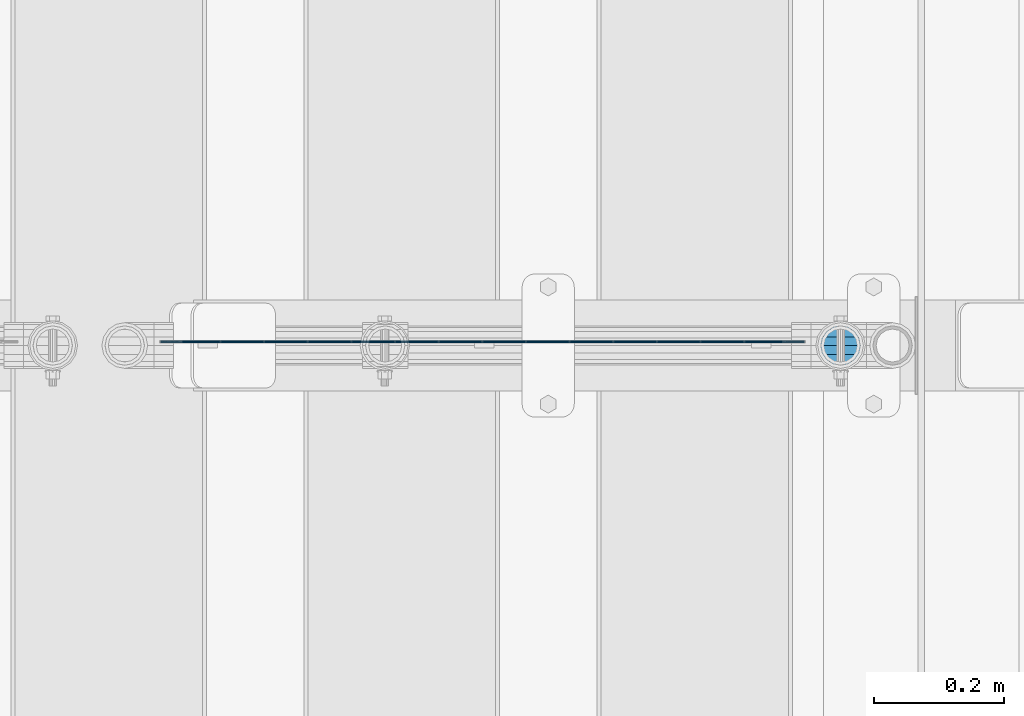
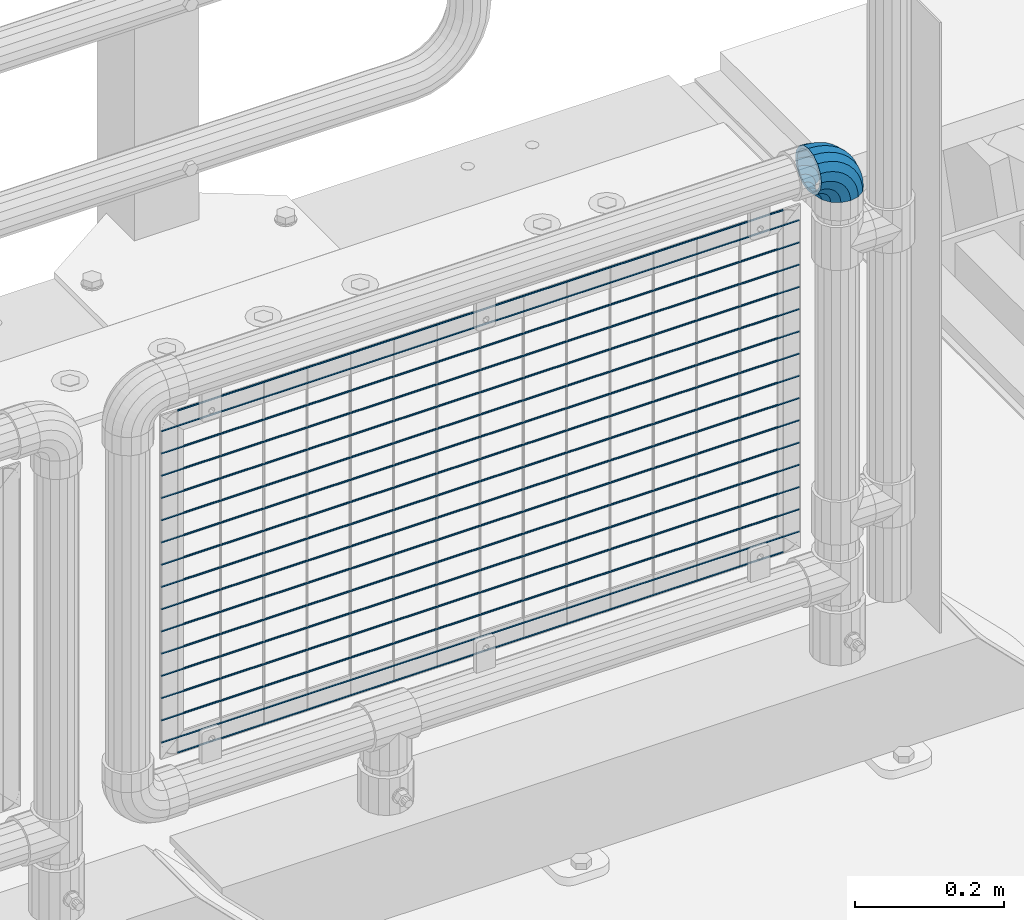
# One storey, part 190 of 270: 17 beams, 1 member.
"""IFC2X3 building model written with IfcOpenShell, lengths in millimetres."""

from ifc_helpers import new_model, si_unit, frame, origin_with_axes, place, context, subcontext, project, spatial, faceted_brep, material, type_object, element, save


model = new_model("IFC2X3")

# Units and contexts
model_context = context("Model", 3, precision=1e-05, world=origin_with_axes())
body_context = subcontext(model_context, "Body", "Model", "MODEL_VIEW")
ifc_project = project(units=[si_unit("LENGTHUNIT", "METRE", prefix="MILLI"), si_unit("AREAUNIT", "SQUARE_METRE"), si_unit("VOLUMEUNIT", "CUBIC_METRE"), si_unit("MASSUNIT", "GRAM", prefix="KILO"), si_unit("TIMEUNIT", "SECOND"), si_unit("PLANEANGLEUNIT", "RADIAN"), si_unit("SOLIDANGLEUNIT", "STERADIAN"), si_unit("THERMODYNAMICTEMPERATUREUNIT", "DEGREE_CELSIUS"), si_unit("LUMINOUSINTENSITYUNIT", "LUMEN")], contexts=[model_context])

# Site, building, storey
site_placement = place(None, origin_with_axes())
site = spatial("IfcSite", under=ifc_project, at=site_placement, CompositionType="ELEMENT")
building_placement = place(site_placement, origin_with_axes())
building = spatial("IfcBuilding", under=site, at=building_placement, Name="Standard", CompositionType="ELEMENT")
storey_placement = place(building_placement, origin_with_axes())
storey = spatial("IfcBuildingStorey", under=building, at=storey_placement, Name="Undefined", CompositionType="ELEMENT", Elevation=0.0)

# Beams
ifc_material = material(Name="Misc_Undefined")
beam_type = type_object("IfcBeamType", Name="D3", PredefinedType="NOTDEFINED")
for number, where, z_axis, x_axis in (
    (1, (18749.61, -16329.5000116654, 633.023), (0.0, 0.0, 1.0), (1.0, 0.0, 0.0)),
    (2, (18749.61, -16329.5000116615, 815.168), (0.0, 0.0, 1.0), (1.0, 0.0, 0.0)),
    (3, (18749.61, -16329.5000116646, 669.452), (0.0, 0.0, 1.0), (1.0, 0.0, 0.0)),
    (4, (18749.61, -16329.5000116662, 596.594000000001), (0.0, 0.0, 1.0), (1.0, 0.0, 0.0)),
    (5, (18749.61, -16329.5000116669, 560.165), (0.0, 0.0, 1.0), (1.0, 0.0, 0.0)),
    (6, (18749.61, -16329.5000116623, 778.739), (0.0, 0.0, 1.0), (1.0, 0.0, 0.0)),
    (7, (18749.61, -16329.5000116677, 523.736), (0.0, 0.0, 1.0), (1.0, 0.0, 0.0)),
    (8, (18749.61, -16329.5000116608, 851.597), (0.0, 0.0, 1.0), (1.0, 0.0, 0.0)),
    (9, (18749.61, -16329.5000116685, 487.307), (0.0, 0.0, 1.0), (1.0, 0.0, 0.0)),
    (10, (18749.61, -16329.5000116639, 705.881), (0.0, 0.0, 1.0), (1.0, 0.0, 0.0)),
    (11, (18749.61, -16329.5000116692, 450.878), (0.0, 0.0, 1.0), (1.0, 0.0, 0.0)),
    (12, (18749.61, -16329.50001166, 888.026), (0.0, 0.0, 1.0), (1.0, 0.0, 0.0)),
    (13, (18749.61, -16329.5000116631, 742.31), (0.0, 0.0, 1.0), (1.0, 0.0, 0.0)),
    (14, (18749.61, -16329.50001167, 414.449), (0.0, 0.0, 1.0), (1.0, 0.0, 0.0)),
):
    element("IfcBeam", number, at=place(storey_placement, frame(where, z_axis=z_axis, x_axis=x_axis)), inside=storey, type_object=beam_type, material=ifc_material, ObjectType="D3", context=body_context, shape_type="Brep", body=[
        faceted_brep([(0.0, -1.5, 0.0), (0.0, -0.75, -1.29903810567669), (988.39000000024, -0.750000000001819, -1.29903810567669), (988.39000000024, -1.50000000000182, 0.0), (0.0, 0.75, -1.29903810567669), (988.390000000243, 0.749999999998181, -1.29903810567669), (0.0, 1.5, 0.0), (988.39000000024, 1.49999999999818, 0.0), (0.0, 0.75, 1.29903810567669), (988.390000000243, 0.749999999998181, 1.29903810567669), (0.0, -0.75, 1.29903810567669), (988.39000000024, -0.750000000001819, 1.29903810567669)], [[[0, 1, 2, 3]], [[1, 4, 5, 2]], [[4, 6, 7, 5]], [[6, 8, 9, 7]], [[8, 10, 11, 9]], [[10, 0, 3, 11]], [[5, 7, 9, 11, 3, 2]], [[10, 8, 6, 4, 1, 0]]]),
    ])
beam_1_placement = place(storey_placement, frame((18774.61, -16329.5000169757, 353.02), z_axis=(0.0, 0.0, 1.0), x_axis=(1.0, 0.0, 0.0)))
element("IfcBeam", 15, at=beam_1_placement, inside=storey, type_object=beam_type, material=ifc_material, ObjectType="D3", context=body_context, shape_type="Brep", body=[
    faceted_brep([(0.0, -1.5, 0.0), (0.0, -0.75, -1.29903810567669), (938.39000000009, -0.750000000003638, -1.29903810567669), (938.390000000094, -1.50000000000364, 0.0), (0.0, 0.75, -1.29903810567669), (938.390000000094, 0.749999999996362, -1.29903810567663), (0.0, 1.5, 0.0), (938.390000000094, 1.49999999999818, 0.0), (0.0, 0.75, 1.29903810567669), (938.390000000094, 0.749999999996362, 1.29903810567669), (0.0, -0.75, 1.29903810567669), (938.39000000009, -0.750000000003638, 1.29903810567669)], [[[0, 1, 2, 3]], [[1, 4, 5, 2]], [[4, 6, 7, 5]], [[6, 8, 9, 7]], [[8, 10, 11, 9]], [[10, 0, 3, 11]], [[5, 7, 9, 11, 3, 2]], [[10, 8, 6, 4, 1, 0]]]),
])
beam_2_placement = place(storey_placement, frame((18749.61, -16329.5000116708, 378.02), z_axis=(0.0, 0.0, 1.0), x_axis=(1.0, 0.0, 0.0)))
element("IfcBeam", 16, at=beam_2_placement, inside=storey, type_object=beam_type, material=ifc_material, ObjectType="D3", context=body_context, shape_type="Brep", body=[
    faceted_brep([(0.0, -1.5, 0.0), (0.0, -0.75, -1.29903810567669), (988.39000000024, -0.750000000001819, -1.29903810567669), (988.39000000024, -1.50000000000182, 0.0), (0.0, 0.75, -1.29903810567669), (988.390000000243, 0.749999999998181, -1.29903810567669), (0.0, 1.5, 0.0), (988.39000000024, 1.49999999999818, 0.0), (0.0, 0.75, 1.29903810567669), (988.390000000243, 0.749999999998181, 1.29903810567669), (0.0, -0.75, 1.29903810567669), (988.39000000024, -0.750000000001819, 1.29903810567669)], [[[0, 1, 2, 3]], [[1, 4, 5, 2]], [[4, 6, 7, 5]], [[6, 8, 9, 7]], [[8, 10, 11, 9]], [[10, 0, 3, 11]], [[5, 7, 9, 11, 3, 2]], [[10, 8, 6, 4, 1, 0]]]),
])
beam_3_placement = place(storey_placement, frame((18774.61, -16329.50001696, 913.02), z_axis=(0.0, 0.0, 1.0), x_axis=(1.0, 0.0, 0.0)))
element("IfcBeam", 17, at=beam_3_placement, inside=storey, type_object=beam_type, material=ifc_material, ObjectType="D3", context=body_context, shape_type="Brep", body=[
    faceted_brep([(0.0, -1.5, 0.0), (0.0, -0.75, -1.29903810567669), (938.39000000009, -0.750000000003638, -1.29903810567669), (938.390000000094, -1.50000000000364, 0.0), (0.0, 0.75, -1.29903810567669), (938.390000000094, 0.749999999996362, -1.29903810567663), (0.0, 1.5, 0.0), (938.390000000094, 1.49999999999818, 0.0), (0.0, 0.75, 1.29903810567669), (938.390000000094, 0.749999999996362, 1.29903810567669), (0.0, -0.75, 1.29903810567669), (938.39000000009, -0.750000000003638, 1.29903810567669)], [[[0, 1, 2, 3]], [[1, 4, 5, 2]], [[4, 6, 7, 5]], [[6, 8, 9, 7]], [[8, 10, 11, 9]], [[10, 0, 3, 11]], [[5, 7, 9, 11, 3, 2]], [[10, 8, 6, 4, 1, 0]]]),
])

# Member
member_type = type_object("IfcMemberType", PredefinedType="NOTDEFINED")
member_placement = place(storey_placement, frame((19794.0, -16335.5, 924.85), z_axis=(0.707106781186547, 0.0, 0.707106781186548), x_axis=(-0.707106781186548, 0.0, 0.707106781186548)))
element("IfcMember", 18, at=member_placement, inside=storey, type_object=member_type, material=ifc_material, context=body_context, shape_type="Brep", body=[
    faceted_brep([(0.0, -35.1499999999996, 0.0), (9.51152146006916, -32.4743655677721, -9.51152146006947), (13.2759578763396, -32.4743655677721, -6.29638902527765), (5.36946880023311, -35.1499999999996, 4.58595959347795), (17.5749999999998, -24.8548033587067, -17.5750000000001), (19.9787556631106, -24.8548033587067, -15.5219987155636), (22.962844107702, -13.4513226476338, -22.9628441077024), (24.4574219585238, -13.4513226476338, -21.686354032394), (24.8548033587069, 0.0, -24.8548033587072), (26.0301204183136, 0.0, -23.8509877588015), (22.962844107702, 13.4513226476338, -22.9628441077024), (24.4574219585238, 13.4513226476338, -21.686354032394), (17.5749999999998, 24.8548033587067, -17.5750000000001), (19.9787556631106, 24.8548033587067, -15.5219987155636), (9.51152146006916, 32.4743655677721, -9.51152146006947), (13.2759578763396, 32.4743655677721, -6.29638902527765), (0.0, 35.1499999999996, 0.0), (5.36946880023311, 35.1499999999996, 4.58595959347795), (-9.51152146006962, 32.4743655677721, 9.5115214600693), (-2.53702027587315, 32.4743655677721, 15.4683082122336), (-17.5750000000003, 24.8548033587067, 17.5749999999999), (-9.23981806264419, 24.8548033587067, 24.6939179025195), (-22.9628441077025, 13.4513226476338, 22.9628441077022), (-13.7184843580576, 13.4513226476338, 30.8582732193499), (-24.8548033587074, 0.0, 24.8548033587071), (-15.2911828178471, 0.0, 33.0229069457573), (-22.9628441077025, -13.4513226476338, 22.9628441077022), (-13.7184843580576, -13.4513226476338, 30.8582732193499), (-17.5750000000003, -24.8548033587067, 17.5749999999999), (-9.23981806264419, -24.8548033587067, 24.6939179025195), (-9.51152146006962, -32.4743655677721, 9.5115214600693), (-2.53702027587315, -32.4743655677721, 15.4683082122336), (0.0, -30.3500000000004, 0.0), (-8.21265081971887, -28.0397438117179, 8.2126508197185), (-1.45732902223699, -28.0397438117179, 13.982240691038), (5.36946880023311, -30.3500000000004, 4.58595959347795), (-15.1750000000002, -21.4606908090118, 15.1749999999999), (-7.24480876131247, -21.4606908090118, 21.9480231689948), (-19.8270929919993, -11.6144421722802, 19.827092991999), (-11.1118790903536, -11.6144421722802, 27.2705888550771), (-21.4606908090118, 0.0, 21.4606908090117), (-12.4698136068432, 0.0, 29.1396253727576), (-19.8270929919993, 11.6144421722802, 19.827092991999), (-11.1118790903536, 11.6144421722802, 27.2705888550771), (-15.1750000000002, 21.4606908090118, 15.1749999999999), (-7.24480876131247, 21.4606908090118, 21.9480231689948), (-8.21265081971887, 28.0397438117179, 8.2126508197185), (-1.45732902223699, 28.0397438117179, 13.982240691038), (0.0, 30.3500000000004, 0.0), (5.36946880023311, 30.3500000000004, 4.58595959347795), (8.21265081971842, 28.0397438117179, -8.21265081971868), (12.1962666227034, 28.0397438117179, -4.81032150408211), (15.1749999999997, 21.4606908090118, -15.175), (17.9837463617789, 21.4606908090118, -12.7761039820388), (19.8270929919988, 11.6144421722802, -19.8270929919991), (21.85081669082, 11.6144421722802, -18.0986696681213), (21.4606908090116, 0.0, -21.4606908090118), (23.2087512073099, 0.0, -19.9677061858016), (19.8270929919988, -11.6144421722802, -19.8270929919991), (21.85081669082, -11.6144421722802, -18.0986696681213), (15.1749999999997, -21.4606908090118, -15.175), (17.9837463617789, -21.4606908090118, -12.7761039820388), (8.21265081971842, -28.0397438117179, -8.21265081971868), (12.1962666227034, -28.0397438117179, -4.81032150408211), (17.4970053560717, -32.4743655677721, -3.70972780292183), (11.390232665115, -35.1499999999996, 8.27548843508188), (22.6740772628625, -24.8548033587067, -13.8703035149452), (26.1332861179524, -13.4513226476338, -20.6593831546809), (27.3479987309599, 0.0, -23.0433908901392), (26.1332861179524, 13.4513226476338, -20.6593831546809), (22.6740772628625, 24.8548033587067, -13.8703035149451), (17.4970053560717, 32.4743655677721, -3.70972780292183), (11.390232665115, 35.1499999999996, 8.27548843508188), (5.28345997415818, 32.4743655677721, 20.2607046730856), (0.106388067367334, 24.8548033587067, 30.4212803851089), (-3.35282078772252, 13.4513226476338, 37.2103600248446), (-4.5675334007301, 0.0, 39.594367760303), (-3.35282078772252, -13.4513226476338, 37.2103600248446), (0.106388067367334, -24.8548033587067, 30.4212803851089), (5.28345997415818, -32.4743655677721, 20.2607046730856), (6.11738625912517, -28.0397438117179, 18.6240321853922), (11.390232665115, -30.3500000000004, 8.27548843508188), (1.64728291997562, -21.4606908090118, 27.3971039595006), (-1.33954464053568, -11.6144421722802, 33.2590831078927), (-2.38837900198041, 0.0, 35.3175364441988), (-1.33954464053568, 11.6144421722802, 33.2590831078927), (1.64728291997562, 21.4606908090118, 27.3971039595006), (6.11738625912517, 28.0397438117179, 18.6240321853922), (11.390232665115, 30.3500000000004, 8.27548843508188), (16.6630790711047, 28.0397438117179, -2.07305531522857), (21.133182410254, 21.4606908090118, -10.8461270893369), (24.1200099707653, 11.6144421722802, -16.7081062377289), (25.16884433221, 0.0, -18.7665595740351), (24.1200099707653, -11.6144421722802, -16.7081062377289), (21.133182410254, -21.4606908090118, -10.8461270893369), (16.6630790711047, -28.0397438117179, -2.07305531522857), (22.070727701461, -32.4743655677721, -1.81522997693261), (17.9140404065217, -35.1499999999996, 10.9777380798872), (25.59459703621, -24.8548033587067, -12.6605846156459), (27.9491712485078, -13.4513226476338, -19.907218905893), (28.7759877588012, 0.0, -22.4518984678874), (27.9491712485078, 13.4513226476338, -19.907218905893), (25.59459703621, 24.8548033587067, -12.6605846156459), (22.070727701461, 32.4743655677721, -1.81522997693261), (17.9140404065217, 35.1499999999996, 10.9777380798872), (13.7573531115827, 32.4743655677721, 23.770706136707), (10.2334837768337, 24.8548033587067, 34.6160607754204), (7.87890956453566, 13.4513226476338, 41.8626950656675), (7.0520930542425, 0.0, 44.4073746276618), (7.87890956453566, -13.4513226476338, 41.8626950656675), (10.2334837768337, -24.8548033587067, 34.6160607754204), (13.7573531115827, -32.4743655677721, 23.770706136707), (14.3249803951021, -28.0397438117179, 22.0237289909678), (17.9140404065217, -30.3500000000004, 10.9777380798872), (11.2823222355109, -21.4606908090118, 31.3880679179933), (9.24928305078129, -11.6144421722802, 37.6451191472678), (8.53537462724216, 0.0, 39.8423033494451), (9.24928305078129, 11.6144421722802, 37.6451191472678), (11.2823222355109, 21.4606908090118, 31.3880679179933), (14.3249803951021, 28.0397438117179, 22.0237289909677), (17.9140404065217, 30.3500000000004, 10.9777380798872), (21.5031004179416, 28.0397438117179, -0.068252831193405), (24.5457585775328, 21.4606908090118, -9.43259175821888), (26.5787977622624, 11.6144421722802, -15.6896429874934), (27.2927061858015, 0.0, -17.8868271896707), (26.5787977622624, -11.6144421722802, -15.6896429874934), (24.5457585775328, -21.4606908090118, -9.43259175821888), (21.5031004179416, -28.0397438117179, -0.068252831193405), (26.8845046890501, -32.4743655677721, -0.65954437126382), (24.7802542265842, -35.1499999999996, 12.6261701733866), (28.6684020936837, -24.8548033587067, -11.9226293117934), (29.8603642316994, -13.4513226476338, -19.4483820661258), (30.2789256727483, 0.0, -22.0910749985325), (29.8603642316994, 13.4513226476338, -19.4483820661258), (28.6684020936837, 24.8548033587067, -11.9226293117934), (26.8845046890501, 32.4743655677721, -0.65954437126382), (24.7802542265842, 35.1499999999996, 12.6261701733866), (22.6760037641182, 32.4743655677721, 25.9118847180369), (20.8921063594846, 24.8548033587067, 37.1749696585664), (19.7001442214689, 13.4513226476338, 44.7007224128988), (19.28158278042, 0.0, 47.3434153453055), (19.7001442214689, -13.4513226476338, 44.7007224128988), (20.8921063594846, -24.8548033587067, 37.1749696585664), (22.6760037641182, -32.4743655677721, 25.9118847180369), (22.9633551786228, -28.0397438117179, 24.0976192894644), (24.7802542265842, -30.3500000000004, 12.6261701733866), (21.4230625404825, -21.4606908090118, 33.8226442665647), (20.393871903533, -11.6144421722802, 40.3206982094946), (20.0324682126131, 0.0, 42.602511310449), (20.393871903533, 11.6144421722802, 40.3206982094946), (21.4230625404825, 21.4606908090118, 33.8226442665647), (22.9633551786228, 28.0397438117179, 24.0976192894644), (24.7802542265842, 30.3500000000004, 12.6261701733866), (26.5971532745455, 28.0397438117179, 1.15472105730865), (28.1374459126855, 21.4606908090118, -8.57030391979166), (29.1666365496353, 11.6144421722802, -15.0683578627215), (29.5280402405551, 0.0, -17.3501709636759), (29.1666365496353, -11.6144421722802, -15.0683578627215), (28.1374459126855, -21.4606908090118, -8.57030391979166), (26.5971532745455, -28.0397438117179, 1.15472105730865), (31.8198051533946, -32.4743655677721, -0.271127801027632), (31.8198051533946, -35.1499999999996, 13.1801948466053), (31.8198051533946, -24.8548033587067, -11.6746085121019), (31.8198051533946, -13.4513226476338, -19.2941707211664), (31.8198051533946, 0.0, -21.9698051533946), (31.8198051533946, 13.4513226476338, -19.2941707211664), (31.8198051533946, 24.8548033587067, -11.6746085121019), (31.8198051533946, 32.4743655677721, -0.271127801027575), (31.8198051533946, 35.1499999999996, 13.1801948466053), (31.8198051533946, 32.4743655677721, 26.6315174942382), (31.8198051533946, 24.8548033587067, 38.0349982053124), (31.8198051533946, 13.4513226476338, 45.654560414377), (31.8198051533946, 0.0, 48.3301948466053), (31.8198051533946, -13.4513226476338, 45.654560414377), (31.8198051533946, -24.8548033587067, 38.0349982053124), (31.8198051533946, -32.4743655677721, 26.6315174942382), (31.8198051533946, -28.0397438117179, 24.7946370188858), (31.8198051533946, -30.3500000000004, 13.1801948466053), (31.8198051533946, -21.4606908090118, 34.640885655617), (31.8198051533946, -11.6144421722802, 41.2199386583228), (31.8198051533946, 0.0, 43.5301948466053), (31.8198051533946, 11.6144421722802, 41.2199386583228), (31.8198051533946, 21.4606908090118, 34.640885655617), (31.8198051533946, 28.0397438117179, 24.7946370188858), (31.8198051533946, 30.3500000000004, 13.1801948466053), (31.8198051533946, 28.0397438117179, 1.56575267432484), (31.8198051533946, 21.4606908090118, -8.28049596240649), (31.8198051533946, 11.6144421722802, -14.8595489651122), (31.8198051533946, 0.0, -17.1698051533947), (31.8198051533946, -11.6144421722802, -14.8595489651122), (31.8198051533946, -21.4606908090118, -8.28049596240649), (31.8198051533946, -28.0397438117179, 1.56575267432484), (36.7551056177388, -32.4743655677721, -0.659544371263877), (38.8593560802049, -35.1499999999996, 12.6261701733865), (34.9712082131055, -24.8548033587067, -11.9226293117935), (33.7792460750895, -13.4513226476338, -19.4483820661258), (33.3606846340408, 0.0, -22.0910749985325), (33.7792460750895, 13.4513226476338, -19.4483820661258), (34.9712082131055, 24.8548033587067, -11.9226293117935), (36.7551056177388, 32.4743655677721, -0.659544371263877), (38.8593560802049, 35.1499999999996, 12.6261701733865), (40.9636065426707, 32.4743655677721, 25.9118847180369), (42.7475039473045, 24.8548033587067, 37.1749696585664), (43.9394660853202, 13.4513226476338, 44.7007224128988), (44.3580275263691, 0.0, 47.3434153453057), (43.9394660853202, -13.4513226476338, 44.7007224128988), (42.7475039473045, -24.8548033587067, 37.1749696585664), (40.9636065426707, -32.4743655677721, 25.9118847180369), (40.6762551281663, -28.0397438117179, 24.0976192894645), (38.8593560802049, -30.3500000000004, 12.6261701733865), (42.2165477663066, -21.4606908090118, 33.8226442665647), (43.2457384032562, -11.6144421722802, 40.3206982094946), (43.6071420941757, 0.0, 42.6025113104489), (43.2457384032562, 11.6144421722802, 40.3206982094946), (42.2165477663066, 21.4606908090118, 33.8226442665647), (40.6762551281663, 28.0397438117179, 24.0976192894645), (38.8593560802049, 30.3500000000004, 12.6261701733865), (37.0424570322434, 28.0397438117179, 1.15472105730865), (35.5021643941034, 21.4606908090118, -8.5703039197916), (34.4729737571538, 11.6144421722802, -15.0683578627216), (34.111570066234, 0.0, -17.3501709636759), (34.4729737571538, -11.6144421722802, -15.0683578627216), (35.5021643941034, -21.4606908090118, -8.5703039197916), (37.0424570322434, -28.0397438117179, 1.15472105730865), (41.5688826053279, -32.4743655677721, -1.81522997693256), (45.7255699002671, -35.1499999999996, 10.9777380798873), (38.0450132705791, -24.8548033587067, -12.6605846156459), (35.6904390582811, -13.4513226476338, -19.907218905893), (34.8636225479877, 0.0, -22.4518984678874), (35.6904390582811, 13.4513226476338, -19.907218905893), (38.0450132705791, 24.8548033587067, -12.6605846156459), (41.5688826053279, 32.4743655677721, -1.81522997693256), (45.7255699002671, 35.1499999999996, 10.9777380798873), (49.8822571952064, 32.4743655677721, 23.7707061367072), (53.4061265299551, 24.8548033587067, 34.6160607754204), (55.7607007422532, 13.4513226476338, 41.8626950656676), (56.5875172525466, 0.0, 44.4073746276619), (55.7607007422532, -13.4513226476338, 41.8626950656676), (53.4061265299551, -24.8548033587067, 34.6160607754204), (49.8822571952064, -32.4743655677721, 23.7707061367072), (49.314629911687, -28.0397438117179, 22.0237289909678), (45.7255699002671, -30.3500000000004, 10.9777380798873), (52.3572880712779, -21.4606908090118, 31.3880679179933), (54.3903272560076, -11.6144421722802, 37.6451191472679), (55.1042356795469, 0.0, 39.8423033494451), (54.3903272560076, 11.6144421722802, 37.6451191472679), (52.3572880712779, 21.4606908090118, 31.3880679179933), (49.3146299116868, 28.0397438117179, 22.0237289909677), (45.7255699002671, 30.3500000000004, 10.9777380798873), (42.1365098888475, 28.0397438117179, -0.0682528311933481), (39.0938517292564, 21.4606908090118, -9.43259175821888), (37.0608125445267, 11.6144421722802, -15.6896429874935), (36.3469041209873, 0.0, -17.8868271896708), (37.0608125445267, -11.6144421722802, -15.6896429874935), (39.0938517292564, -21.4606908090118, -9.43259175821888), (42.1365098888475, -28.0397438117179, -0.0682528311933481), (46.1426049507174, -32.4743655677721, -3.70972780292183), (52.2493776416741, -35.1499999999996, 8.27548843508177), (40.9655330439266, -24.8548033587067, -13.8703035149451), (37.5063241888367, -13.4513226476338, -20.6593831546809), (36.2916115758289, 0.0, -23.0433908901393), (37.5063241888367, 13.4513226476338, -20.6593831546809), (40.9655330439266, 24.8548033587067, -13.8703035149451), (46.1426049507174, 32.4743655677721, -3.70972780292183), (52.2493776416741, 35.1499999999996, 8.27548843508177), (58.3561503326309, 32.4743655677721, 20.2607046730855), (63.5332222394218, 24.8548033587067, 30.421280385109), (66.9924310945114, 13.4513226476338, 37.2103600248446), (68.2071437075192, 0.0, 39.594367760303), (66.9924310945114, -13.4513226476338, 37.2103600248446), (63.5332222394218, -24.8548033587067, 30.421280385109), (58.3561503326309, -32.4743655677721, 20.2607046730855), (57.5222240476637, -28.0397438117179, 18.6240321853922), (52.2493776416741, -30.3500000000004, 8.27548843508177), (61.9923273868133, -21.4606908090118, 27.3971039595006), (64.9791549473246, -11.6144421722802, 33.2590831078926), (66.0279893087693, 0.0, 35.3175364441988), (64.9791549473246, 11.6144421722802, 33.2590831078926), (61.9923273868133, 21.4606908090118, 27.3971039595006), (57.5222240476637, 28.0397438117179, 18.6240321853922), (52.2493776416741, 30.3500000000004, 8.27548843508177), (46.9765312356844, 28.0397438117179, -2.07305531522863), (42.5064278965349, 21.4606908090118, -10.846127089337), (39.5196003360236, 11.6144421722802, -16.708106237729), (38.4707659745789, 0.0, -18.766559574035), (39.5196003360236, -11.6144421722802, -16.708106237729), (42.5064278965349, -21.4606908090118, -10.846127089337), (46.9765312356844, -28.0397438117179, -2.07305531522863), (50.3636524304493, -32.4743655677721, -6.29638902527759), (58.2701415065558, -35.1499999999996, 4.58595959347801), (43.6608546436782, -24.8548033587067, -15.5219987155636), (39.1821883482653, -13.4513226476338, -21.686354032394), (37.6094898884753, 0.0, -23.8509877588015), (39.1821883482653, 13.4513226476338, -21.686354032394), (43.6608546436782, 24.8548033587067, -15.5219987155636), (50.3636524304493, 32.4743655677721, -6.29638902527759), (58.2701415065558, 35.1499999999996, 4.58595959347801), (66.1766305826623, 32.4743655677721, 15.4683082122336), (72.8794283694331, 24.8548033587067, 24.6939179025195), (77.3580946648465, 13.4513226476338, 30.8582732193499), (78.9307931246362, 0.0, 33.0229069457573), (77.3580946648465, -13.4513226476338, 30.8582732193499), (72.8794283694331, -24.8548033587067, 24.6939179025195), (66.1766305826623, -32.4743655677721, 15.4683082122336), (65.0969393290261, -28.0397438117179, 13.982240691038), (58.2701415065558, -30.3500000000004, 4.58595959347801), (70.8844190681016, -21.4606908090118, 21.9480231689947), (74.7514893971425, -11.6144421722802, 27.2705888550772), (76.1094239136323, 0.0, 29.1396253727577), (74.7514893971425, 11.6144421722802, 27.2705888550772), (70.8844190681016, 21.4606908090118, 21.9480231689947), (65.0969393290261, 28.0397438117179, 13.982240691038), (58.2701415065558, 30.3500000000004, 4.58595959347801), (51.4433436840854, 28.0397438117179, -4.81032150408205), (45.65586394501, 21.4606908090118, -12.7761039820388), (41.7887936159691, 11.6144421722802, -18.0986696681213), (40.4308590994792, 0.0, -19.9677061858017), (41.7887936159691, -11.6144421722802, -18.0986696681213), (45.65586394501, -21.4606908090118, -12.7761039820388), (51.4433436840854, -28.0397438117179, -4.81032150408205), (54.1280888467197, -32.4743655677721, -9.51152146006942), (63.6396103067891, -35.1499999999996, -2.8421709430404e-14), (46.0646103067891, -24.8548033587067, -17.5750000000001), (40.6767661990866, -13.4513226476338, -22.9628441077024), (38.784806948082, 0.0, -24.8548033587072), (40.6767661990866, 13.4513226476338, -22.9628441077024), (46.0646103067891, 24.8548033587067, -17.5750000000001), (54.1280888467197, 32.4743655677721, -9.51152146006942), (63.6396103067891, 35.1499999999996, -2.8421709430404e-14), (73.1511317668585, 32.4743655677721, 9.51152146006936), (81.2146103067892, 24.8548033587067, 17.575), (86.6024544144916, 13.4513226476338, 22.9628441077024), (88.4944136654963, 0.0, 24.8548033587071), (86.6024544144916, -13.4513226476338, 22.9628441077024), (81.2146103067892, -24.8548033587067, 17.575), (73.1511317668585, -32.4743655677721, 9.51152146006936), (71.8522611265075, -28.0397438117179, 8.2126508197185), (63.6396103067891, -30.3500000000004, -2.8421709430404e-14), (78.8146103067891, -21.4606908090118, 15.1749999999999), (83.4667032987882, -11.6144421722802, 19.827092991999), (85.1003011158009, 0.0, 21.4606908090117), (83.4667032987882, 11.6144421722802, 19.827092991999), (78.8146103067891, 21.4606908090118, 15.1749999999999), (71.8522611265075, 28.0397438117179, 8.2126508197185), (63.6396103067891, 30.3500000000004, -2.8421709430404e-14), (55.4269594870707, 28.0397438117179, -8.21265081971856), (48.4646103067892, 21.4606908090118, -15.175), (43.8125173147901, 11.6144421722802, -19.8270929919991), (42.1789194977773, 0.0, -21.4606908090117), (43.8125173147901, -11.6144421722802, -19.8270929919991), (48.4646103067892, -21.4606908090118, -15.175), (55.4269594870707, -28.0397438117179, -8.21265081971856)], [[[0, 1, 2, 3]], [[1, 4, 5, 2]], [[4, 6, 7, 5]], [[6, 8, 9, 7]], [[8, 10, 11, 9]], [[10, 12, 13, 11]], [[12, 14, 15, 13]], [[14, 16, 17, 15]], [[16, 18, 19, 17]], [[18, 20, 21, 19]], [[20, 22, 23, 21]], [[22, 24, 25, 23]], [[24, 26, 27, 25]], [[26, 28, 29, 27]], [[28, 30, 31, 29]], [[30, 0, 3, 31]], [[32, 33, 34, 35]], [[33, 36, 37, 34]], [[36, 38, 39, 37]], [[38, 40, 41, 39]], [[40, 42, 43, 41]], [[42, 44, 45, 43]], [[44, 46, 47, 45]], [[46, 48, 49, 47]], [[48, 50, 51, 49]], [[50, 52, 53, 51]], [[52, 54, 55, 53]], [[54, 56, 57, 55]], [[56, 58, 59, 57]], [[58, 60, 61, 59]], [[60, 62, 63, 61]], [[62, 32, 35, 63]], [[30, 28, 26, 24, 22, 20, 18, 16, 14, 12, 10, 8, 6, 4, 1, 0], [62, 60, 58, 56, 54, 52, 50, 48, 46, 44, 42, 40, 38, 36, 33, 32]], [[3, 2, 64, 65]], [[2, 5, 66, 64]], [[5, 7, 67, 66]], [[7, 9, 68, 67]], [[9, 11, 69, 68]], [[11, 13, 70, 69]], [[13, 15, 71, 70]], [[15, 17, 72, 71]], [[17, 19, 73, 72]], [[19, 21, 74, 73]], [[21, 23, 75, 74]], [[23, 25, 76, 75]], [[25, 27, 77, 76]], [[27, 29, 78, 77]], [[29, 31, 79, 78]], [[31, 3, 65, 79]], [[35, 34, 80, 81]], [[34, 37, 82, 80]], [[37, 39, 83, 82]], [[39, 41, 84, 83]], [[41, 43, 85, 84]], [[43, 45, 86, 85]], [[45, 47, 87, 86]], [[47, 49, 88, 87]], [[49, 51, 89, 88]], [[51, 53, 90, 89]], [[53, 55, 91, 90]], [[55, 57, 92, 91]], [[57, 59, 93, 92]], [[59, 61, 94, 93]], [[61, 63, 95, 94]], [[63, 35, 81, 95]], [[65, 64, 96, 97]], [[64, 66, 98, 96]], [[66, 67, 99, 98]], [[67, 68, 100, 99]], [[68, 69, 101, 100]], [[69, 70, 102, 101]], [[70, 71, 103, 102]], [[71, 72, 104, 103]], [[72, 73, 105, 104]], [[73, 74, 106, 105]], [[74, 75, 107, 106]], [[75, 76, 108, 107]], [[76, 77, 109, 108]], [[77, 78, 110, 109]], [[78, 79, 111, 110]], [[79, 65, 97, 111]], [[81, 80, 112, 113]], [[80, 82, 114, 112]], [[82, 83, 115, 114]], [[83, 84, 116, 115]], [[84, 85, 117, 116]], [[85, 86, 118, 117]], [[86, 87, 119, 118]], [[87, 88, 120, 119]], [[88, 89, 121, 120]], [[89, 90, 122, 121]], [[90, 91, 123, 122]], [[91, 92, 124, 123]], [[92, 93, 125, 124]], [[93, 94, 126, 125]], [[94, 95, 127, 126]], [[95, 81, 113, 127]], [[97, 96, 128, 129]], [[96, 98, 130, 128]], [[98, 99, 131, 130]], [[99, 100, 132, 131]], [[100, 101, 133, 132]], [[101, 102, 134, 133]], [[102, 103, 135, 134]], [[103, 104, 136, 135]], [[104, 105, 137, 136]], [[105, 106, 138, 137]], [[106, 107, 139, 138]], [[107, 108, 140, 139]], [[108, 109, 141, 140]], [[109, 110, 142, 141]], [[110, 111, 143, 142]], [[111, 97, 129, 143]], [[113, 112, 144, 145]], [[112, 114, 146, 144]], [[114, 115, 147, 146]], [[115, 116, 148, 147]], [[116, 117, 149, 148]], [[117, 118, 150, 149]], [[118, 119, 151, 150]], [[119, 120, 152, 151]], [[120, 121, 153, 152]], [[121, 122, 154, 153]], [[122, 123, 155, 154]], [[123, 124, 156, 155]], [[124, 125, 157, 156]], [[125, 126, 158, 157]], [[126, 127, 159, 158]], [[127, 113, 145, 159]], [[129, 128, 160, 161]], [[128, 130, 162, 160]], [[130, 131, 163, 162]], [[131, 132, 164, 163]], [[132, 133, 165, 164]], [[133, 134, 166, 165]], [[134, 135, 167, 166]], [[135, 136, 168, 167]], [[136, 137, 169, 168]], [[137, 138, 170, 169]], [[138, 139, 171, 170]], [[139, 140, 172, 171]], [[140, 141, 173, 172]], [[141, 142, 174, 173]], [[142, 143, 175, 174]], [[143, 129, 161, 175]], [[145, 144, 176, 177]], [[144, 146, 178, 176]], [[146, 147, 179, 178]], [[147, 148, 180, 179]], [[148, 149, 181, 180]], [[149, 150, 182, 181]], [[150, 151, 183, 182]], [[151, 152, 184, 183]], [[152, 153, 185, 184]], [[153, 154, 186, 185]], [[154, 155, 187, 186]], [[155, 156, 188, 187]], [[156, 157, 189, 188]], [[157, 158, 190, 189]], [[158, 159, 191, 190]], [[159, 145, 177, 191]], [[161, 160, 192, 193]], [[160, 162, 194, 192]], [[162, 163, 195, 194]], [[163, 164, 196, 195]], [[164, 165, 197, 196]], [[165, 166, 198, 197]], [[166, 167, 199, 198]], [[167, 168, 200, 199]], [[168, 169, 201, 200]], [[169, 170, 202, 201]], [[170, 171, 203, 202]], [[171, 172, 204, 203]], [[172, 173, 205, 204]], [[173, 174, 206, 205]], [[174, 175, 207, 206]], [[175, 161, 193, 207]], [[177, 176, 208, 209]], [[176, 178, 210, 208]], [[178, 179, 211, 210]], [[179, 180, 212, 211]], [[180, 181, 213, 212]], [[181, 182, 214, 213]], [[182, 183, 215, 214]], [[183, 184, 216, 215]], [[184, 185, 217, 216]], [[185, 186, 218, 217]], [[186, 187, 219, 218]], [[187, 188, 220, 219]], [[188, 189, 221, 220]], [[189, 190, 222, 221]], [[190, 191, 223, 222]], [[191, 177, 209, 223]], [[193, 192, 224, 225]], [[192, 194, 226, 224]], [[194, 195, 227, 226]], [[195, 196, 228, 227]], [[196, 197, 229, 228]], [[197, 198, 230, 229]], [[198, 199, 231, 230]], [[199, 200, 232, 231]], [[200, 201, 233, 232]], [[201, 202, 234, 233]], [[202, 203, 235, 234]], [[203, 204, 236, 235]], [[204, 205, 237, 236]], [[205, 206, 238, 237]], [[206, 207, 239, 238]], [[207, 193, 225, 239]], [[209, 208, 240, 241]], [[208, 210, 242, 240]], [[210, 211, 243, 242]], [[211, 212, 244, 243]], [[212, 213, 245, 244]], [[213, 214, 246, 245]], [[214, 215, 247, 246]], [[215, 216, 248, 247]], [[216, 217, 249, 248]], [[217, 218, 250, 249]], [[218, 219, 251, 250]], [[219, 220, 252, 251]], [[220, 221, 253, 252]], [[221, 222, 254, 253]], [[222, 223, 255, 254]], [[223, 209, 241, 255]], [[225, 224, 256, 257]], [[224, 226, 258, 256]], [[226, 227, 259, 258]], [[227, 228, 260, 259]], [[228, 229, 261, 260]], [[229, 230, 262, 261]], [[230, 231, 263, 262]], [[231, 232, 264, 263]], [[232, 233, 265, 264]], [[233, 234, 266, 265]], [[234, 235, 267, 266]], [[235, 236, 268, 267]], [[236, 237, 269, 268]], [[237, 238, 270, 269]], [[238, 239, 271, 270]], [[239, 225, 257, 271]], [[241, 240, 272, 273]], [[240, 242, 274, 272]], [[242, 243, 275, 274]], [[243, 244, 276, 275]], [[244, 245, 277, 276]], [[245, 246, 278, 277]], [[246, 247, 279, 278]], [[247, 248, 280, 279]], [[248, 249, 281, 280]], [[249, 250, 282, 281]], [[250, 251, 283, 282]], [[251, 252, 284, 283]], [[252, 253, 285, 284]], [[253, 254, 286, 285]], [[254, 255, 287, 286]], [[255, 241, 273, 287]], [[257, 256, 288, 289]], [[256, 258, 290, 288]], [[258, 259, 291, 290]], [[259, 260, 292, 291]], [[260, 261, 293, 292]], [[261, 262, 294, 293]], [[262, 263, 295, 294]], [[263, 264, 296, 295]], [[264, 265, 297, 296]], [[265, 266, 298, 297]], [[266, 267, 299, 298]], [[267, 268, 300, 299]], [[268, 269, 301, 300]], [[269, 270, 302, 301]], [[270, 271, 303, 302]], [[271, 257, 289, 303]], [[273, 272, 304, 305]], [[272, 274, 306, 304]], [[274, 275, 307, 306]], [[275, 276, 308, 307]], [[276, 277, 309, 308]], [[277, 278, 310, 309]], [[278, 279, 311, 310]], [[279, 280, 312, 311]], [[280, 281, 313, 312]], [[281, 282, 314, 313]], [[282, 283, 315, 314]], [[283, 284, 316, 315]], [[284, 285, 317, 316]], [[285, 286, 318, 317]], [[286, 287, 319, 318]], [[287, 273, 305, 319]], [[289, 288, 320, 321]], [[288, 290, 322, 320]], [[290, 291, 323, 322]], [[291, 292, 324, 323]], [[292, 293, 325, 324]], [[293, 294, 326, 325]], [[294, 295, 327, 326]], [[295, 296, 328, 327]], [[296, 297, 329, 328]], [[297, 298, 330, 329]], [[298, 299, 331, 330]], [[299, 300, 332, 331]], [[300, 301, 333, 332]], [[301, 302, 334, 333]], [[302, 303, 335, 334]], [[303, 289, 321, 335]], [[305, 304, 336, 337]], [[304, 306, 338, 336]], [[306, 307, 339, 338]], [[307, 308, 340, 339]], [[308, 309, 341, 340]], [[309, 310, 342, 341]], [[310, 311, 343, 342]], [[311, 312, 344, 343]], [[312, 313, 345, 344]], [[313, 314, 346, 345]], [[314, 315, 347, 346]], [[315, 316, 348, 347]], [[316, 317, 349, 348]], [[317, 318, 350, 349]], [[318, 319, 351, 350]], [[319, 305, 337, 351]], [[322, 323, 324, 325, 326, 327, 328, 329, 330, 331, 332, 333, 334, 335, 321, 320], [338, 339, 340, 341, 342, 343, 344, 345, 346, 347, 348, 349, 350, 351, 337, 336]]]),
])

save(model, "model.ifc")
